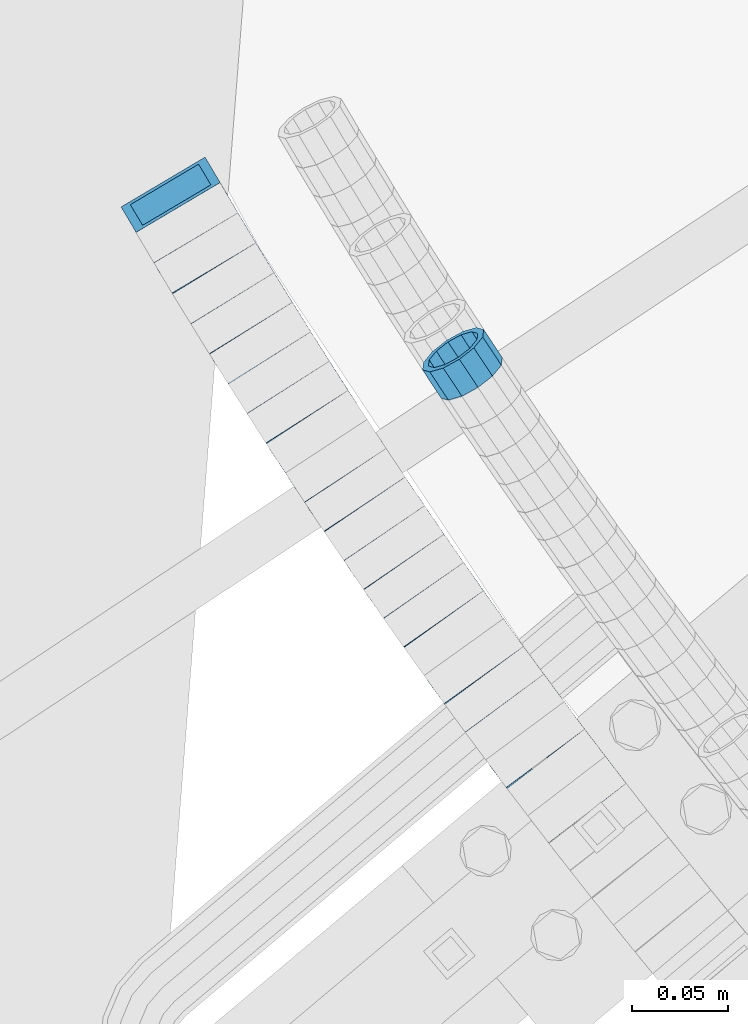
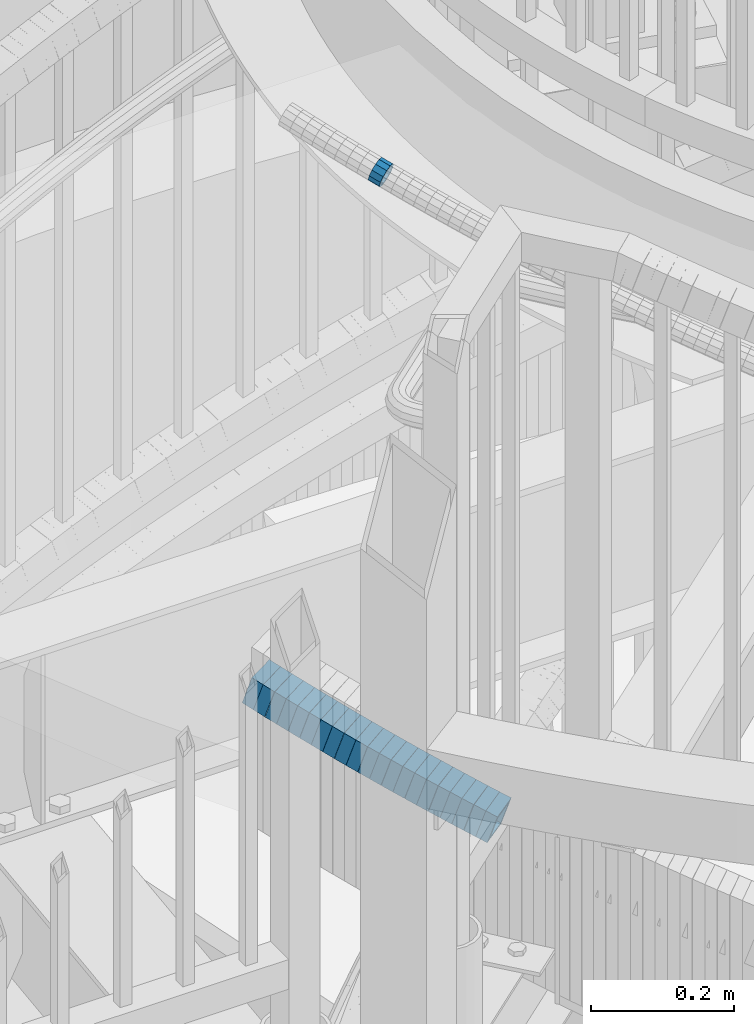
# One storey, part 656 of 975: 22 beams.
"""IFC2X3 building model written with IfcOpenShell, lengths in millimetres."""

import ifcopenshell
import ifcopenshell.guid

model = None  # the IFC model being written
_history = None  # IfcOwnerHistory: only IFC2X3 demands one
_inside = {}  # id of a spatial element -> (the spatial element, [elements in it])
_under = {}  # id of a project, library or spatial element -> (it, [spatial elements below it])
_declared = {}  # id of a project -> (the project, [libraries it declares])
_typed = {}  # id of a type object -> (the type object, [elements of that type])
_made_of = {}  # id of a material, layer set ... -> (it, [elements and type objects made of it])


def new_model(schema):
    """Start an empty IFC model of exactly this schema.

    Asked for "IFC4X3", IfcOpenShell would pick the latest addendum, in which some entities
    have other attributes; the version numbers below select the first issue.
    IFC2X3 requires an IfcOwnerHistory on every rooted entity: one is made here for all.
    """
    global model, _history
    if schema == "IFC4X3":
        model = ifcopenshell.file(schema_version=(4, 3, 0, 0))
    else:
        model = ifcopenshell.file(schema=schema)
    _inside.clear()
    _under.clear()
    _declared.clear()
    _typed.clear()
    _made_of.clear()
    _history = None
    if model.schema == "IFC2X3":
        org = make("IfcOrganization", Name="unknown")
        user = make(
            "IfcPersonAndOrganization",
            ThePerson=make("IfcPerson", FamilyName="unknown"),
            TheOrganization=org,
        )
        app = make(
            "IfcApplication",
            ApplicationDeveloper=org,
            Version="unknown",
            ApplicationFullName="unknown",
            ApplicationIdentifier="unknown",
        )
        _history = make(
            "IfcOwnerHistory",
            OwningUser=user,
            OwningApplication=app,
            ChangeAction="ADDED",
            CreationDate=0,
        )
    return model


def make(cls, **values):
    """One entity of the class cls with the attributes given. An attribute that is None is left unset."""
    return model.create_entity(
        cls, **{name: value for name, value in values.items() if value is not None}
    )


def rooted(cls, **values):
    """An entity with a GlobalId (a new one), such as an element, a storey or a relation."""
    return make(cls, GlobalId=ifcopenshell.guid.new(), OwnerHistory=_history, **values)


def si_unit(unit_type, name, prefix=None):
    """IfcSIUnit, for example si_unit("LENGTHUNIT", "METRE", prefix="MILLI")."""
    return make("IfcSIUnit", UnitType=unit_type, Prefix=prefix, Name=name)


def assignment(units):
    """IfcUnitAssignment: the units of a project."""
    return None if units is None else make("IfcUnitAssignment", Units=units)


def point(xyz):
    """IfcCartesianPoint."""
    return None if xyz is None else make("IfcCartesianPoint", Coordinates=xyz)


def direction(xyz):
    """IfcDirection."""
    return None if xyz is None else make("IfcDirection", DirectionRatios=xyz)


def frame(location, z_axis=None, x_axis=None):
    """IfcAxis2Placement3D, a coordinate frame: its origin and axes. An axis left out is left unset."""
    return make(
        "IfcAxis2Placement3D",
        Location=point(location),
        Axis=direction(z_axis),
        RefDirection=direction(x_axis),
    )


def origin_with_axes():
    """The frame at (0, 0, 0) with the z axis (0, 0, 1) and the x axis (1, 0, 0) written out."""
    return frame((0.0, 0.0, 0.0), z_axis=(0.0, 0.0, 1.0), x_axis=(1.0, 0.0, 0.0))


def place(relative_to, where):
    """IfcLocalPlacement: puts the frame where relative to a parent placement (None: the world)."""
    return make(
        "IfcLocalPlacement", PlacementRelTo=relative_to, RelativePlacement=where
    )


def context(
    kind, dimensions, precision=None, world=None, true_north=None, identifier=None
):
    """IfcGeometricRepresentationContext, for example the 3D "Model" context."""
    return make(
        "IfcGeometricRepresentationContext",
        ContextIdentifier=identifier,
        ContextType=kind,
        CoordinateSpaceDimension=dimensions,
        Precision=precision,
        WorldCoordinateSystem=world,
        TrueNorth=true_north,
    )


def subcontext(parent, identifier, kind, view, scale=None):
    """IfcGeometricRepresentationSubContext, for example "Body" below "Model"."""
    return make(
        "IfcGeometricRepresentationSubContext",
        ContextIdentifier=identifier,
        ContextType=kind,
        ParentContext=parent,
        TargetScale=scale,
        TargetView=view,
    )


def project(units=None, contexts=None):
    """IfcProject with its units and contexts."""
    return rooted(
        "IfcProject",
        Name="project",
        RepresentationContexts=contexts,
        UnitsInContext=assignment(units),
    )


def spatial(cls, under=None, at=None, **own):
    """A site, building, storey or space (cls), placed at a placement, below another one or the project."""
    s = rooted(cls, ObjectPlacement=at, **own)
    if under is not None:
        _under.setdefault(under.id(), (under, []))[1].append(s)
    return s


def faces_of(points, faces, orient=None, outer=None):
    """IfcFace entities. A face is a list of loops; a loop is a list of indices into points, from 0.

    orient and outer hold one flag for each loop. By default every Orientation is true, the
    first loop of a face is its IfcFaceOuterBound and the others are IfcFaceBound.
    """
    made = []
    for i, loops in enumerate(faces):
        bounds = []
        for j, loop in enumerate(loops):
            is_outer = j == 0 if outer is None else outer[i][j]
            bounds.append(
                make(
                    "IfcFaceOuterBound" if is_outer else "IfcFaceBound",
                    Bound=make("IfcPolyLoop", Polygon=[points[k] for k in loop]),
                    Orientation=True if orient is None else orient[i][j],
                )
            )
        made.append(make("IfcFace", Bounds=bounds))
    return made


def faceted_brep(points, faces, orient=None, outer=None, voids=None):
    """IfcFacetedBrep: a solid bounded by flat faces; with voids (closed shells), ...WithVoids."""
    shared = [point(p) for p in points]
    hull = make("IfcClosedShell", CfsFaces=faces_of(shared, faces, orient, outer))
    if voids is None:
        return make("IfcFacetedBrep", Outer=hull)
    return make(
        "IfcFacetedBrepWithVoids",
        Outer=hull,
        Voids=[
            make(cls, CfsFaces=faces_of(shared, fs, o, b)) for cls, fs, o, b in voids
        ],
    )


def shape(context_of_items, identifier, shape_type, items):
    """IfcShapeRepresentation: the items that make up one representation, for example the "Body"."""
    return make(
        "IfcShapeRepresentation",
        ContextOfItems=context_of_items,
        RepresentationIdentifier=identifier,
        RepresentationType=shape_type,
        Items=items,
    )


def material(Name=None, Category=None):
    """IfcMaterial."""
    return make("IfcMaterial", Name=Name, Category=Category)


def made_of(thing, what):
    """Note that an element or type object is made of a material, layer set ...; save() writes the relation."""
    if what is not None:
        _made_of.setdefault(what.id(), (what, []))[1].append(thing)
    return thing


def type_object(cls, material=None, **own):
    """A type object (cls), such as IfcWallType, which elements share."""
    return made_of(rooted(cls, **own), material)


def element(
    cls,
    number,
    at=None,
    inside=None,
    cuts=None,
    type_object=None,
    material=None,
    context=None,
    identifier="Body",
    shape_type=None,
    held_by="IfcProductDefinitionShape",
    body=None,
    shapes=None,
    **own,
):
    """One element of the class cls, such as IfcWall. Its Tag is "e" and its number.

    at: its placement. inside: the storey or other place that contains it. cuts: it is an
    opening in that element (IfcRelVoidsElement). A single representation is given by context,
    identifier, shape_type and body (its items); several are given by shapes. held_by: the class
    of the entity that holds the representations. save() writes the other relations.
    """
    e = rooted(cls, Tag="e%d" % number, ObjectPlacement=at, **own)
    if body is not None:
        shapes = [shape(context, identifier, shape_type, body)]
    if shapes is not None:
        e.Representation = make(held_by, Representations=shapes)
    if inside is not None:
        _inside.setdefault(inside.id(), (inside, []))[1].append(e)
    if cuts is not None:
        rooted(
            "IfcRelVoidsElement", RelatingBuildingElement=cuts, RelatedOpeningElement=e
        )
    if type_object is not None:
        _typed.setdefault(type_object.id(), (type_object, []))[1].append(e)
    return made_of(e, material)


def aggregate(whole, parts):
    """IfcRelAggregates: a whole, such as a stair, and the parts it consists of."""
    return rooted("IfcRelAggregates", RelatingObject=whole, RelatedObjects=parts)


def save(model, path):
    """Write the relations noted so far, then the file.

    IfcRelAggregates (storeys below a building ...), IfcRelContainedInSpatialStructure (elements
    in a storey), IfcRelDefinesByType, IfcRelAssociatesMaterial and IfcRelDeclares: one each for
    every whole, place, type object, material and project.
    """
    for whole, parts in _under.values():
        aggregate(whole, parts)
    for where, things in _inside.values():
        rooted(
            "IfcRelContainedInSpatialStructure",
            RelatedElements=things,
            RelatingStructure=where,
        )
    for kind, things in _typed.values():
        rooted("IfcRelDefinesByType", RelatedObjects=things, RelatingType=kind)
    for what, things in _made_of.values():
        rooted("IfcRelAssociatesMaterial", RelatedObjects=things, RelatingMaterial=what)
    for by, libraries in _declared.values():
        rooted("IfcRelDeclares", RelatingContext=by, RelatedDefinitions=libraries)
    model.write(path)


model = new_model("IFC2X3")

# Units and contexts
model_context = context("Model", 3, precision=1e-05, world=origin_with_axes())
body_context = subcontext(model_context, "Body", "Model", "MODEL_VIEW")
ifc_project = project(units=[si_unit("LENGTHUNIT", "METRE", prefix="MILLI"), si_unit("AREAUNIT", "SQUARE_METRE"), si_unit("VOLUMEUNIT", "CUBIC_METRE"), si_unit("MASSUNIT", "GRAM", prefix="KILO"), si_unit("TIMEUNIT", "SECOND"), si_unit("PLANEANGLEUNIT", "RADIAN"), si_unit("SOLIDANGLEUNIT", "STERADIAN"), si_unit("THERMODYNAMICTEMPERATUREUNIT", "DEGREE_CELSIUS"), si_unit("LUMINOUSINTENSITYUNIT", "LUMEN")], contexts=[model_context])

# Site, building, storey
site_placement = place(None, origin_with_axes())
site = spatial("IfcSite", under=ifc_project, at=site_placement, CompositionType="ELEMENT")
building_placement = place(site_placement, origin_with_axes())
building = spatial("IfcBuilding", under=site, at=building_placement, Name="Undefined", CompositionType="ELEMENT")
storey_placement = place(building_placement, origin_with_axes())
storey = spatial("IfcBuildingStorey", under=building, at=storey_placement, Name="Undefined", CompositionType="ELEMENT", Elevation=0.0)

# Beams
ifc_material = material()
beam_type_1 = type_object("IfcBeamType", PredefinedType="NOTDEFINED")
beam_1_placement = place(storey_placement, frame((32397.0147372931, 1885.18095695464, 5117.00592832306), z_axis=(0.834661610484996, 0.550763103323556, 9.69521352089941e-13), x_axis=(0.523125832185072, -0.792778323280461, -0.312796889110645)))
element("IfcBeam", 1, at=beam_1_placement, inside=storey, type_object=beam_type_1, material=ifc_material, Name="WALL", context=body_context, shape_type="Brep", body=[
    faceted_brep([(-2.1246523829177e-07, -15.367000000002, 0.0), (-1.83998054126278e-07, -13.3082123799541, 7.68350000000009), (18.5442713526427, -13.3082123799486, 7.68349999999555), (18.544271352639, -15.3669999999893, -1.81898940354586e-12), (-1.06232619145885e-07, -7.68349999999919, 13.3082123799559), (18.5442713526427, -7.68349999999373, 13.3082123799541), (-3.63797880709171e-12, 3.63797880709171e-12, 15.3670000000002), (18.5442713526354, 5.45696821063757e-12, 15.3669999999947), (1.06225343188271e-07, 7.68350000000646, 13.3082123799559), (18.5442713526245, 7.68350000001192, 13.3082123799468), (1.8399441614747e-07, 13.308212379965, 7.68350000000009), (18.5442713526172, 13.3082123799704, 7.68349999998827), (2.12461600312963e-07, 15.3670000000093, 0.0), (18.5442713526027, 15.3670000000202, -1.45519152283669e-11), (1.8399441614747e-07, 13.308212379965, -7.68350000000009), (18.5442713526027, 13.3082123799759, -7.68350000001556), (1.06225343188271e-07, 7.68350000000646, -13.3082123799559), (18.5442713526027, 7.68350000002283, -13.3082123799686), (-3.63797880709171e-12, 3.63797880709171e-12, -15.3670000000002), (18.5442713526063, 2.18278728425503e-11, -15.3670000000129), (-1.06232619145885e-07, -7.68349999999919, -13.3082123799559), (18.5442713526209, -7.68349999998281, -13.3082123799632), (-1.83998054126278e-07, -13.3082123799541, -7.68350000000009), (18.5442713526318, -13.3082123799395, -7.68350000000646), (-2.63386027654633e-07, -19.0500000000029, 0.0), (-2.28097633225843e-07, -16.4977839420972, -9.52499999999964), (18.5442713526354, -16.4977839420808, -9.52500000000691), (18.5442713526427, -19.0499999999902, -1.81898940354586e-12), (-1.31691194837913e-07, -9.52500000000146, -16.4977839420935), (18.5442713526245, -9.52499999997963, -16.4977839421044), (-3.63797880709171e-12, 3.63797880709171e-12, -19.0500000000002), (18.5442713526099, 2.36468622460961e-11, -19.0500000000138), (1.31687556859106e-07, 9.52500000000509, -16.4977839420935), (18.544271352599, 9.5250000000251, -16.4977839421081), (2.28097633225843e-07, 16.4977839421044, -9.52499999999964), (18.5442713525917, 16.4977839421172, -9.52500000001601), (2.63382389675826e-07, 19.0500000000138, 0.0), (18.544271352599, 19.0500000000211, -1.45519152283669e-11), (2.28097633225843e-07, 16.4977839421044, 9.52499999999964), (18.5442713526136, 16.4977839421099, 9.52499999998872), (1.31687556859106e-07, 9.52500000000509, 16.4977839420935), (18.5442713526281, 9.52500000000873, 16.4977839420862), (-3.63797880709171e-12, 3.63797880709171e-12, 19.0500000000002), (18.5442713526427, 3.63797880709171e-12, 19.0499999999975), (-1.31691194837913e-07, -9.52500000000146, 16.4977839420935), (18.54427135265, -9.524999999996, 16.4977839420935), (-2.28097633225843e-07, -16.4977839420972, 9.52499999999964), (18.54427135265, -16.4977839420899, 9.52499999999964)], [[[0, 1, 2, 3]], [[1, 4, 5, 2]], [[4, 6, 7, 5]], [[6, 8, 9, 7]], [[8, 10, 11, 9]], [[10, 12, 13, 11]], [[12, 14, 15, 13]], [[14, 16, 17, 15]], [[16, 18, 19, 17]], [[18, 20, 21, 19]], [[20, 22, 23, 21]], [[22, 0, 3, 23]], [[24, 25, 26, 27]], [[25, 28, 29, 26]], [[28, 30, 31, 29]], [[30, 32, 33, 31]], [[32, 34, 35, 33]], [[34, 36, 37, 35]], [[36, 38, 39, 37]], [[38, 40, 41, 39]], [[40, 42, 43, 41]], [[42, 44, 45, 43]], [[44, 46, 47, 45]], [[46, 24, 27, 47]], [[29, 31, 33, 35, 37, 39, 41, 43, 45, 47, 27, 26], [5, 7, 9, 11, 13, 15, 17, 19, 21, 23, 3, 2]], [[46, 44, 42, 40, 38, 36, 34, 32, 30, 28, 25, 24], [22, 20, 18, 16, 14, 12, 10, 8, 6, 4, 1, 0]]]),
])
beam_type_2 = type_object("IfcBeamType", Name="HSS2X2X.188_TUBES", PredefinedType="NOTDEFINED")
beam_2_placement = place(storey_placement, frame((32250.0902876863, 1965.7485546787, 4242.99334868471), z_axis=(0.860380537679217, 0.509652166072923, 7.19055606168696e-11), x_axis=(0.485707570135991, -0.819957940229565, -0.302914398084807)))
element("IfcBeam", 2, at=beam_2_placement, inside=storey, type_object=beam_type_2, material=ifc_material, Name="WALL", ObjectType="HSS2X2X.188_TUBES", context=body_context, shape_type="Brep", body=[
    faceted_brep([(0.0, 20.6374999999753, -20.6375000000298), (0.0, -20.6375000000153, -20.6375000000153), (19.1473235727644, -20.6374999999953, -20.637500000008), (19.1473235727499, 20.6374999999935, -20.6375000000262), (0.0, -20.6374999999825, 20.6375000000335), (19.1473235727899, -20.6375000000007, 20.6375000000444), (0.0, 20.6375000000116, 20.6375000000189), (19.1473235727772, 20.637499999988, 20.6375000000226), (0.0, 25.3999999999724, -25.4000000000342), (0.0, 25.400000000016, 25.4000000000196), (19.1473235727753, 25.3999999999851, 25.4000000000306), (19.1473235727462, 25.3999999999942, -25.4000000000342), (0.0, -25.399999999976, 25.4000000000378), (19.1473235727935, -25.4000000000015, 25.4000000000487), (0.0, -25.400000000016, -25.4000000000196), (19.1473235727608, -25.3999999999942, -25.400000000016)], [[[0, 1, 2, 3]], [[1, 4, 5, 2]], [[4, 6, 7, 5]], [[6, 0, 3, 7]], [[8, 9, 10, 11]], [[9, 12, 13, 10]], [[12, 14, 15, 13]], [[14, 8, 11, 15]], [[13, 15, 11, 10], [5, 7, 3, 2]], [[14, 12, 9, 8], [6, 4, 1, 0]]]),
])
beam_3_placement = place(storey_placement, frame((32259.3294549026, 1950.10823719607, 4237.24272757799), z_axis=(0.858946974184472, 0.512064542357055, 6.8944245867897e-11), x_axis=(0.48701112800018, -0.816921892000355, -0.308964049000125)))
element("IfcBeam", 3, at=beam_3_placement, inside=storey, type_object=beam_type_2, material=ifc_material, Name="WALL", ObjectType="HSS2X2X.188_TUBES", context=body_context, shape_type="Brep", body=[
    faceted_brep([(0.0, 20.6374999999753, -20.6375000000298), (0.0, -20.6375000000153, -20.6375000000153), (19.0960728947011, -20.6374999999935, -20.6375000000153), (19.0960728946884, 20.6374999999971, -20.6375000000335), (0.0, -20.6374999999825, 20.6375000000335), (19.0960728947157, -20.6375000000062, 20.6375000000226), (0.0, 20.6375000000116, 20.6375000000189), (19.096072894703, 20.6374999999844, 20.637500000008), (0.0, 25.3999999999724, -25.4000000000342), (0.0, 25.400000000016, 25.4000000000196), (19.096072894703, 25.3999999999796, 25.4000000000124), (19.0960728946866, 25.399999999996, -25.4000000000378), (0.0, -25.399999999976, 25.4000000000378), (19.0960728947175, -25.4000000000051, 25.4000000000269), (0.0, -25.400000000016, -25.4000000000196), (19.0960728946993, -25.3999999999905, -25.4000000000196)], [[[0, 1, 2, 3]], [[1, 4, 5, 2]], [[4, 6, 7, 5]], [[6, 0, 3, 7]], [[8, 9, 10, 11]], [[9, 12, 13, 10]], [[12, 14, 15, 13]], [[14, 8, 11, 15]], [[13, 15, 11, 10], [5, 7, 3, 2]], [[14, 12, 9, 8], [6, 4, 1, 0]]]),
])
beam_4_placement = place(storey_placement, frame((32268.7748844232, 1934.08308993233, 4231.30167783261), z_axis=(0.852601252575669, 0.522562057660523, -1.88316334970295e-10), x_axis=(0.497839568037742, -0.812264559061597, -0.303944157023068)))
element("IfcBeam", 4, at=beam_4_placement, inside=storey, type_object=beam_type_2, material=ifc_material, Name="WALL", ObjectType="HSS2X2X.188_TUBES", context=body_context, shape_type="Brep", body=[
    faceted_brep([(0.0, 20.6374999999753, -20.6375000000298), (0.0, -20.6375000000153, -20.6375000000153), (19.0824526725246, -20.6375000000098, -20.6375000000262), (19.0824526725428, 20.6375000000044, -20.6375000000044), (0.0, -20.6374999999825, 20.6375000000335), (19.0824526725391, -20.6375000000153, 20.6374999999898), (0.0, 20.6375000000116, 20.6375000000189), (19.0824526725555, 20.6374999999971, 20.6375000000153), (0.0, 25.3999999999724, -25.4000000000342), (0.0, 25.400000000016, 25.4000000000196), (19.0824526725592, 25.3999999999996, 25.4000000000233), (19.0824526725428, 25.4000000000069, -25.4000000000015), (0.0, -25.399999999976, 25.4000000000378), (19.0824526725391, -25.4000000000178, 25.3999999999905), (0.0, -25.400000000016, -25.4000000000196), (19.082452672521, -25.4000000000106, -25.4000000000342)], [[[0, 1, 2, 3]], [[1, 4, 5, 2]], [[4, 6, 7, 5]], [[6, 0, 3, 7]], [[8, 9, 10, 11]], [[9, 12, 13, 10]], [[12, 14, 15, 13]], [[14, 8, 11, 15]], [[13, 15, 11, 10], [5, 7, 3, 2]], [[14, 12, 9, 8], [6, 4, 1, 0]]]),
])
beam_5_placement = place(storey_placement, frame((32278.2770067394, 1918.5369817553, 4225.51221989357), z_axis=(0.851088555876138, 0.52502216149099, 1.54790541273541e-10), x_axis=(0.49996537788202, -0.810470190808751, -0.305242019927984)))
element("IfcBeam", 5, at=beam_5_placement, inside=storey, type_object=beam_type_2, material=ifc_material, Name="WALL", ObjectType="HSS2X2X.188_TUBES", context=body_context, shape_type="Brep", body=[
    faceted_brep([(0.0, 20.6374999999753, -20.6375000000298), (0.0, -20.6375000000153, -20.6375000000153), (19.0013157439425, -20.637500000008, -20.6374999999607), (19.0013157439371, 20.6374999999971, -20.637499999968), (0.0, -20.6374999999825, 20.6375000000335), (19.0013157439262, -20.6374999999935, 20.6375000000116), (0.0, 20.6375000000116, 20.6375000000189), (19.0013157439207, 20.6375000000116, 20.637500000008), (0.0, 25.3999999999724, -25.4000000000342), (0.0, 25.400000000016, 25.4000000000196), (19.0013157439171, 25.4000000000124, 25.4000000000015), (19.0013157439407, 25.399999999996, -25.3999999999651), (0.0, -25.399999999976, 25.4000000000378), (19.0013157439244, -25.3999999999924, 25.4000000000087), (0.0, -25.400000000016, -25.4000000000196), (19.0013157439444, -25.4000000000087, -25.3999999999578)], [[[0, 1, 2, 3]], [[1, 4, 5, 2]], [[4, 6, 7, 5]], [[6, 0, 3, 7]], [[8, 9, 10, 11]], [[9, 12, 13, 10]], [[12, 14, 15, 13]], [[14, 8, 11, 15]], [[13, 15, 11, 10], [5, 7, 3, 2]], [[14, 12, 9, 8], [6, 4, 1, 0]]]),
])
beam_6_placement = place(storey_placement, frame((32287.8196908273, 1902.99924574157, 4219.70568187766), z_axis=(0.84861688225198, 0.529007927310102, 2.10578946280293e-10), x_axis=(0.503897090052248, -0.80833491408383, -0.304437825031588)))
element("IfcBeam", 6, at=beam_6_placement, inside=storey, type_object=beam_type_2, material=ifc_material, Name="WALL", ObjectType="HSS2X2X.188_TUBES", context=body_context, shape_type="Brep", body=[
    faceted_brep([(0.0, 20.6374999999753, -20.6375000000298), (0.0, -20.6375000000153, -20.6375000000153), (19.0515091265825, -20.6374999999989, -20.6374999999825), (19.0515091265752, 20.6375000000116, -20.6375000000044), (0.0, -20.6374999999825, 20.6375000000335), (19.0515091265916, -20.6375000000207, 20.637500000048), (0.0, 20.6375000000116, 20.6375000000189), (19.0515091265843, 20.6374999999898, 20.6375000000262), (0.0, 25.3999999999724, -25.4000000000342), (0.0, 25.400000000016, 25.4000000000196), (19.0515091265825, 25.3999999999887, 25.4000000000269), (19.0515091265715, 25.4000000000142, -25.400000000016), (0.0, -25.399999999976, 25.4000000000378), (19.0515091265952, -25.4000000000251, 25.4000000000597), (0.0, -25.400000000016, -25.4000000000196), (19.0515091265825, -25.3999999999978, -25.3999999999833)], [[[0, 1, 2, 3]], [[1, 4, 5, 2]], [[4, 6, 7, 5]], [[6, 0, 3, 7]], [[8, 9, 10, 11]], [[9, 12, 13, 10]], [[12, 14, 15, 13]], [[14, 8, 11, 15]], [[13, 15, 11, 10], [5, 7, 3, 2]], [[14, 12, 9, 8], [6, 4, 1, 0]]]),
])
for number, where, z_axis, x_axis, name in (
    (7, (32297.4695969665, 1887.36640821885, 4213.92011794034), (0.842975720116068, 0.537951610551354, -1.41735654324293e-10), (0.512110492189128, -0.802482421296357, -0.306210397113073), "WALL"),
    (8, (32307.1695969665, 1872.16640821885, 4208.12011794034), (0.842975720116068, 0.537951610551354, -1.41735654324293e-10), (0.512110492189128, -0.802482421296357, -0.306210397113073), "WALL"),
):
    element("IfcBeam", number, at=place(storey_placement, frame(where, z_axis=z_axis, x_axis=x_axis)), inside=storey, type_object=beam_type_2, material=ifc_material, Name=name, ObjectType="HSS2X2X.188_TUBES", context=body_context, shape_type="Brep", body=[
        faceted_brep([(0.0, 20.6374999999753, -20.6375000000298), (0.0, -20.6375000000153, -20.6375000000153), (18.9372648500248, -20.6375000000098, -20.6374999999716), (18.9372648499939, 20.637500000008, -20.6375000000189), (0.0, -20.6374999999825, 20.6375000000335), (18.9372648500175, -20.6375000000007, 20.6375000000116), (0.0, 20.6375000000116, 20.6375000000189), (18.9372648499884, 20.6375000000153, 20.6374999999643), (0.0, 25.3999999999724, -25.4000000000342), (0.0, 25.400000000016, 25.4000000000196), (18.9372648499811, 25.4000000000196, 25.3999999999578), (18.9372648499884, 25.4000000000087, -25.4000000000233), (0.0, -25.399999999976, 25.4000000000378), (18.9372648500193, -25.4000000000033, 25.400000000016), (0.0, -25.400000000016, -25.4000000000196), (18.9372648500266, -25.4000000000124, -25.3999999999651)], [[[0, 1, 2, 3]], [[1, 4, 5, 2]], [[4, 6, 7, 5]], [[6, 0, 3, 7]], [[8, 9, 10, 11]], [[9, 12, 13, 10]], [[12, 14, 15, 13]], [[14, 8, 11, 15]], [[13, 15, 11, 10], [5, 7, 3, 2]], [[14, 12, 9, 8], [6, 4, 1, 0]]]),
    ])
beam_7_placement = place(storey_placement, frame((32316.9144109529, 1856.82948907239, 4202.31335669337), z_axis=(0.840459118679731, 0.541874957742181, -1.38352334033698e-11), x_axis=(0.515989619098183, -0.800310430152245, -0.3053816110581)))
element("IfcBeam", 9, at=beam_7_placement, inside=storey, type_object=beam_type_2, material=ifc_material, Name="WALL", ObjectType="HSS2X2X.188_TUBES", context=body_context, shape_type="Brep", body=[
    faceted_brep([(0.0, 20.6374999999753, -20.6375000000298), (0.0, -20.6375000000153, -20.6375000000153), (18.9907872401272, -20.6375000000025, -20.6374999999789), (18.9907872401127, 20.6375000000007, -20.6375000000116), (0.0, -20.6374999999825, 20.6375000000335), (18.9907872401418, -20.6375000000171, 20.6375000000626), (0.0, 20.6375000000116, 20.6375000000189), (18.9907872401291, 20.6374999999862, 20.6375000000298), (0.0, 25.3999999999724, -25.4000000000342), (0.0, 25.400000000016, 25.4000000000196), (18.9907872401272, 25.3999999999851, 25.4000000000306), (18.9907872401072, 25.4000000000033, -25.4000000000196), (0.0, -25.399999999976, 25.4000000000378), (18.9907872401473, -25.4000000000196, 25.4000000000669), (0.0, -25.400000000016, -25.4000000000196), (18.9907872401254, -25.4000000000015, -25.3999999999833)], [[[0, 1, 2, 3]], [[1, 4, 5, 2]], [[4, 6, 7, 5]], [[6, 0, 3, 7]], [[8, 9, 10, 11]], [[9, 12, 13, 10]], [[12, 14, 15, 13]], [[14, 8, 11, 15]], [[13, 15, 11, 10], [5, 7, 3, 2]], [[14, 12, 9, 8], [6, 4, 1, 0]]]),
])
beam_8_placement = place(storey_placement, frame((32326.7691270212, 1841.39318044604, 4196.52755469662), z_axis=(0.834609406352343, 0.550842208647984, 2.89660420094152e-10), x_axis=(0.524220597122522, -0.794273631185618, -0.307119137071787)))
element("IfcBeam", 10, at=beam_8_placement, inside=storey, type_object=beam_type_2, material=ifc_material, Name="WALL", ObjectType="HSS2X2X.188_TUBES", context=body_context, shape_type="Brep", body=[
    faceted_brep([(0.0, 20.6374999999753, -20.6375000000298), (0.0, -20.6375000000153, -20.6375000000153), (18.891267824034, -20.6375000000153, -20.6374999999971), (18.891267824034, 20.6375000000025, -20.637500000008), (0.0, -20.6374999999825, 20.6375000000335), (18.8912678240486, -20.6374999999989, 20.6375000000153), (0.0, 20.6375000000116, 20.6375000000189), (18.8912678240449, 20.6375000000189, 20.6375000000007), (0.0, 25.3999999999724, -25.4000000000342), (0.0, 25.400000000016, 25.4000000000196), (18.8912678240467, 25.4000000000215, 25.4000000000051), (18.8912678240304, 25.4000000000033, -25.4000000000124), (0.0, -25.399999999976, 25.4000000000378), (18.8912678240504, -25.3999999999996, 25.400000000016), (0.0, -25.400000000016, -25.4000000000196), (18.891267824034, -25.4000000000178, -25.3999999999978)], [[[0, 1, 2, 3]], [[1, 4, 5, 2]], [[4, 6, 7, 5]], [[6, 0, 3, 7]], [[8, 9, 10, 11]], [[9, 12, 13, 10]], [[12, 14, 15, 13]], [[14, 8, 11, 15]], [[13, 15, 11, 10], [5, 7, 3, 2]], [[14, 12, 9, 8], [6, 4, 1, 0]]]),
])
beam_9_placement = place(storey_placement, frame((32336.7160547092, 1826.25719176891, 4190.72057137198), z_axis=(0.832050294630691, 0.554700195785959, -1.70329258253332e-10), x_axis=(0.528044638140129, -0.79206695721017, -0.306265890081285)))
element("IfcBeam", 11, at=beam_9_placement, inside=storey, type_object=beam_type_2, material=ifc_material, Name="WALL", ObjectType="HSS2X2X.188_TUBES", context=body_context, shape_type="Brep", body=[
    faceted_brep([(0.0, 20.6374999999753, -20.6375000000298), (0.0, -20.6375000000153, -20.6375000000153), (18.9372648500248, -20.6375000000098, -20.6374999999716), (18.9372648499939, 20.637500000008, -20.6375000000189), (0.0, -20.6374999999825, 20.6375000000335), (18.9372648500175, -20.6375000000007, 20.6375000000116), (0.0, 20.6375000000116, 20.6375000000189), (18.9372648499884, 20.6375000000153, 20.6374999999643), (0.0, 25.3999999999724, -25.4000000000342), (0.0, 25.400000000016, 25.4000000000196), (18.9372648499811, 25.4000000000196, 25.3999999999578), (18.9372648499884, 25.4000000000087, -25.4000000000233), (0.0, -25.399999999976, 25.4000000000378), (18.9372648500193, -25.4000000000033, 25.400000000016), (0.0, -25.400000000016, -25.4000000000196), (18.9372648500266, -25.4000000000124, -25.3999999999651)], [[[0, 1, 2, 3]], [[1, 4, 5, 2]], [[4, 6, 7, 5]], [[6, 0, 3, 7]], [[8, 9, 10, 11]], [[9, 12, 13, 10]], [[12, 14, 15, 13]], [[14, 8, 11, 15]], [[13, 15, 11, 10], [5, 7, 3, 2]], [[14, 12, 9, 8], [6, 4, 1, 0]]]),
])
beam_10_placement = place(storey_placement, frame((32346.8379493841, 1810.96921421217, 4184.8850393727), z_axis=(0.827752230488746, 0.561093793336645, -2.60712113231421e-10), x_axis=(0.534915910017351, -0.789133373025616, -0.301883237009813)))
element("IfcBeam", 12, at=beam_10_placement, inside=storey, type_object=beam_type_2, material=ifc_material, Name="WALL", ObjectType="HSS2X2X.188_TUBES", context=body_context, shape_type="Brep", body=[
    faceted_brep([(0.0, 20.6374999999753, -20.6375000000298), (0.0, -20.6375000000153, -20.6375000000153), (18.8814724002259, -20.6375000000171, -20.6374999999753), (18.8814724002277, 20.6374999999916, -20.6374999999716), (0.0, -20.6374999999825, 20.6375000000335), (18.8814724002368, -20.6375000000062, 20.6375000000298), (0.0, 20.6375000000116, 20.6375000000189), (18.8814724002386, 20.6375000000025, 20.6375000000262), (0.0, 25.3999999999724, -25.4000000000342), (0.0, 25.400000000016, 25.4000000000196), (18.8814724002386, 25.4000000000051, 25.4000000000269), (18.8814724002277, 25.3999999999905, -25.399999999976), (0.0, -25.399999999976, 25.4000000000378), (18.8814724002368, -25.4000000000051, 25.4000000000269), (0.0, -25.400000000016, -25.4000000000196), (18.8814724002259, -25.4000000000196, -25.399999999976)], [[[0, 1, 2, 3]], [[1, 4, 5, 2]], [[4, 6, 7, 5]], [[6, 0, 3, 7]], [[8, 9, 10, 11]], [[9, 12, 13, 10]], [[12, 14, 15, 13]], [[14, 8, 11, 15]], [[13, 15, 11, 10], [5, 7, 3, 2]], [[14, 12, 9, 8], [6, 4, 1, 0]]]),
])
beam_11_placement = place(storey_placement, frame((32356.8757291109, 1796.1175697729, 4179.23451134792), z_axis=(0.825991119591471, 0.56368312938745, 1.78134541783948e-10), x_axis=(0.536286546161279, -0.78584563123631, -0.307966531092603)))
element("IfcBeam", 13, at=beam_11_placement, inside=storey, type_object=beam_type_2, material=ifc_material, Name="WALL", ObjectType="HSS2X2X.188_TUBES", context=body_context, shape_type="Brep", body=[
    faceted_brep([(0.0, 20.6374999999753, -20.6375000000298), (0.0, -20.6375000000153, -20.6375000000153), (18.8332159191086, -20.6374999999916, -20.6375000000153), (18.8332159190923, 20.6375000000062, -20.6375000000335), (0.0, -20.6374999999825, 20.6375000000335), (18.8332159191377, -20.6375000000062, 20.6375000000335), (0.0, 20.6375000000116, 20.6375000000189), (18.8332159191141, 20.6374999999916, 20.6375000000116), (0.0, 25.3999999999724, -25.4000000000342), (0.0, 25.400000000016, 25.4000000000196), (18.8332159191159, 25.3999999999905, 25.4000000000124), (18.8332159190886, 25.4000000000069, -25.4000000000415), (0.0, -25.399999999976, 25.4000000000378), (18.8332159191395, -25.4000000000069, 25.4000000000378), (0.0, -25.400000000016, -25.4000000000196), (18.8332159191104, -25.3999999999905, -25.400000000016)], [[[0, 1, 2, 3]], [[1, 4, 5, 2]], [[4, 6, 7, 5]], [[6, 0, 3, 7]], [[8, 9, 10, 11]], [[9, 12, 13, 10]], [[12, 14, 15, 13]], [[14, 8, 11, 15]], [[13, 15, 11, 10], [5, 7, 3, 2]], [[14, 12, 9, 8], [6, 4, 1, 0]]]),
])
beam_12_placement = place(storey_placement, frame((32367.1015560726, 1781.02831328982, 4173.39843596918), z_axis=(0.821588113548792, 0.570081548267734, 1.52022039401345e-10), x_axis=(0.54318366524401, -0.782823517351607, -0.303543813136327)))
element("IfcBeam", 14, at=beam_12_placement, inside=storey, type_object=beam_type_2, material=ifc_material, Name="WALL", ObjectType="HSS2X2X.188_TUBES", context=body_context, shape_type="Brep", body=[
    faceted_brep([(0.0, 20.6374999999753, -20.6375000000298), (0.0, -20.6375000000153, -20.6375000000153), (18.7771137292038, -20.637500000008, -20.6374999999862), (18.777113729182, 20.6375000000062, -20.6375000000189), (0.0, -20.6374999999825, 20.6375000000335), (18.7771137291729, -20.6374999999916, 20.6374999999753), (0.0, 20.6375000000116, 20.6375000000189), (18.7771137291529, 20.6375000000207, 20.6374999999389), (0.0, 25.3999999999724, -25.4000000000342), (0.0, 25.400000000016, 25.4000000000196), (18.7771137291475, 25.4000000000251, 25.3999999999287), (18.7771137291857, 25.4000000000051, -25.4000000000196), (0.0, -25.399999999976, 25.4000000000378), (18.7771137291711, -25.3999999999905, 25.3999999999724), (0.0, -25.400000000016, -25.4000000000196), (18.7771137292129, -25.4000000000124, -25.3999999999724)], [[[0, 1, 2, 3]], [[1, 4, 5, 2]], [[4, 6, 7, 5]], [[6, 0, 3, 7]], [[8, 9, 10, 11]], [[9, 12, 13, 10]], [[12, 14, 15, 13]], [[14, 8, 11, 15]], [[13, 15, 11, 10], [5, 7, 3, 2]], [[14, 12, 9, 8], [6, 4, 1, 0]]]),
])
beam_13_placement = place(storey_placement, frame((32377.2895230482, 1766.23986054821, 4167.74096997326), z_axis=(0.817122939314853, 0.576463443806678, -1.1019528756151e-10), x_axis=(0.548299120091774, -0.777200694130069, -0.308750961051663)))
element("IfcBeam", 15, at=beam_13_placement, inside=storey, type_object=beam_type_2, material=ifc_material, Name="WALL", ObjectType="HSS2X2X.188_TUBES", context=body_context, shape_type="Brep", body=[
    faceted_brep([(0.0, 20.6374999999753, -20.6375000000298), (0.0, -20.6375000000153, -20.6375000000153), (18.7853666454903, -20.6375000000535, -20.6375000000326), (18.785366645363, 20.6374999999862, -20.6375000000044), (0.0, -20.6374999999825, 20.6375000000335), (18.785366645352, -20.6375000000007, 20.6374999999989), (0.0, 20.6375000000116, 20.6375000000189), (18.7853666453102, 20.6375000000025, 20.6374999999753), (0.0, 25.3999999999724, -25.4000000000342), (0.0, 25.400000000016, 25.4000000000196), (18.7853666452065, 25.4000000000451, 25.4000000000351), (18.7853666453739, 25.3999999999833, -25.400000000006), (0.0, -25.399999999976, 25.4000000000378), (18.7853666497213, -25.399999993424, 25.3999999995158), (0.0, -25.400000000016, -25.4000000000196), (18.7853666455194, -25.4000000000633, -25.4000000000406)], [[[0, 1, 2, 3]], [[1, 4, 5, 2]], [[4, 6, 7, 5]], [[6, 0, 3, 7]], [[8, 9, 10, 11]], [[9, 12, 13, 10]], [[12, 14, 15, 13]], [[14, 8, 11, 15]], [[13, 15, 11, 10], [5, 7, 3, 2]], [[14, 12, 9, 8], [6, 4, 1, 0]]]),
])
beam_14_placement = place(storey_placement, frame((32387.7115850864, 1751.40643299604, 4161.89430571694), z_axis=(0.814486661793431, 0.580182279771275, -2.11284714168869e-11), x_axis=(0.552902161305901, -0.776189572429466, -0.303032915167687)))
element("IfcBeam", 16, at=beam_14_placement, inside=storey, type_object=beam_type_2, material=ifc_material, Name="WALL", ObjectType="HSS2X2X.188_TUBES", context=body_context, shape_type="Brep", body=[
    faceted_brep([(0.0, 20.6374999999753, -20.6375000000298), (0.0, -20.6375000000153, -20.6375000000153), (18.8066477608099, -20.6374999999862, -20.6375000000116), (18.8066477608172, 20.6375000000062, -20.6374999999971), (0.0, -20.6374999999825, 20.6375000000335), (18.8066477608463, -20.6375000000062, 20.6375000000407), (0.0, 20.6375000000116, 20.6375000000189), (18.8066477608536, 20.6374999999844, 20.637500000048), (0.0, 25.3999999999724, -25.4000000000342), (0.0, 25.400000000016, 25.4000000000196), (18.8066477608591, 25.3999999999814, 25.400000000056), (18.8066477608154, 25.4000000000051, -25.4000000000015), (0.0, -25.399999999976, 25.4000000000378), (18.8066477608518, -25.4000000000087, 25.4000000000451), (0.0, -25.400000000016, -25.4000000000196), (18.8066477608081, -25.3999999999851, -25.4000000000196)], [[[0, 1, 2, 3]], [[1, 4, 5, 2]], [[4, 6, 7, 5]], [[6, 0, 3, 7]], [[8, 9, 10, 11]], [[9, 12, 13, 10]], [[12, 14, 15, 13]], [[14, 8, 11, 15]], [[13, 15, 11, 10], [5, 7, 3, 2]], [[14, 12, 9, 8], [6, 4, 1, 0]]]),
])
beam_15_placement = place(storey_placement, frame((32398.1206864209, 1736.75057400697, 4156.20445651513), z_axis=(0.812595948879356, 0.582827439183211, 7.00165401212871e-11), x_axis=(0.555190025760515, -0.774063016666067, -0.304286840868723)))
element("IfcBeam", 17, at=beam_15_placement, inside=storey, type_object=beam_type_2, material=ifc_material, Name="WALL", ObjectType="HSS2X2X.188_TUBES", context=body_context, shape_type="Brep", body=[
    faceted_brep([(0.0, 20.6374999999753, -20.6375000000298), (0.0, -20.6375000000153, -20.6375000000153), (18.7347271129966, -20.6375000000116, -20.6375000000262), (18.7347271130257, 20.6374999999989, -20.6374999999935), (0.0, -20.6374999999825, 20.6375000000335), (18.7347271129947, -20.6375000000116, 20.6374999999607), (0.0, 20.6375000000116, 20.6375000000189), (18.7347271130147, 20.6375000000007, 20.6374999999898), (0.0, 25.3999999999724, -25.4000000000342), (0.0, 25.400000000016, 25.4000000000196), (18.7347271130166, 25.4000000000015, 25.3999999999905), (18.7347271130257, 25.3999999999996, -25.3999999999869), (0.0, -25.399999999976, 25.4000000000378), (18.7347271129875, -25.4000000000106, 25.3999999999505), (0.0, -25.400000000016, -25.4000000000196), (18.7347271130002, -25.4000000000124, -25.4000000000233)], [[[0, 1, 2, 3]], [[1, 4, 5, 2]], [[4, 6, 7, 5]], [[6, 0, 3, 7]], [[8, 9, 10, 11]], [[9, 12, 13, 10]], [[12, 14, 15, 13]], [[14, 8, 11, 15]], [[13, 15, 11, 10], [5, 7, 3, 2]], [[14, 12, 9, 8], [6, 4, 1, 0]]]),
])
beam_16_placement = place(storey_placement, frame((32408.6363838666, 1721.92913766419, 4150.49986562592), z_axis=(0.805336884073592, 0.592817428177207, 3.1585841497872e-11), x_axis=(0.564813441940968, -0.767293732919835, -0.303720435968248)))
element("IfcBeam", 18, at=beam_16_placement, inside=storey, type_object=beam_type_2, material=ifc_material, Name="WALL", ObjectType="HSS2X2X.188_TUBES", context=body_context, shape_type="Brep", body=[
    faceted_brep([(0.0, 20.6374999999753, -20.6375000000298), (0.0, -20.6375000000153, -20.6375000000153), (18.767258723612, -20.6375000000025, -20.6374999999862), (18.7672587236229, 20.6374999999953, -20.637499999968), (0.0, -20.6374999999825, 20.6375000000335), (18.767258723612, -20.6375000000135, 20.6375000000153), (0.0, 20.6375000000116, 20.6375000000189), (18.7672587236266, 20.6374999999844, 20.6375000000371), (0.0, 25.3999999999724, -25.4000000000342), (0.0, 25.400000000016, 25.4000000000196), (18.7672587236302, 25.3999999999814, 25.4000000000342), (18.7672587236229, 25.399999999996, -25.3999999999687), (0.0, -25.399999999976, 25.4000000000378), (18.7672587236157, -25.4000000000142, 25.400000000016), (0.0, -25.400000000016, -25.4000000000196), (18.767258723612, -25.4000000000015, -25.3999999999905)], [[[0, 1, 2, 3]], [[1, 4, 5, 2]], [[4, 6, 7, 5]], [[6, 0, 3, 7]], [[8, 9, 10, 11]], [[9, 12, 13, 10]], [[12, 14, 15, 13]], [[14, 8, 11, 15]], [[13, 15, 11, 10], [5, 7, 3, 2]], [[14, 12, 9, 8], [6, 4, 1, 0]]]),
])
beam_17_placement = place(storey_placement, frame((32419.1739275642, 1707.57001396563, 4144.84968740492), z_axis=(0.803358108992866, 0.595496220571891, -1.10680048237555e-10), x_axis=(0.566197633066482, -0.763832656089715, -0.309806252036406)))
element("IfcBeam", 19, at=beam_17_placement, inside=storey, type_object=beam_type_2, material=ifc_material, Name="WALL", ObjectType="HSS2X2X.188_TUBES", context=body_context, shape_type="Brep", body=[
    faceted_brep([(0.0, 20.6374999999753, -20.6375000000298), (0.0, -20.6375000000153, -20.6375000000153), (18.724849799155, -20.6375000000171, -20.6374999999425), (18.7248497991204, 20.6374999999989, -20.6375000000007), (0.0, -20.6374999999825, 20.6375000000335), (18.7248497991168, -20.6374999999953, 20.6375000000007), (0.0, 20.6375000000116, 20.6375000000189), (18.724849799084, 20.6375000000226, 20.6374999999498), (0.0, 25.3999999999724, -25.4000000000342), (0.0, 25.400000000016, 25.4000000000196), (18.7248497990731, 25.4000000000269, 25.399999999936), (18.7248497991204, 25.3999999999978, -25.3999999999978), (0.0, -25.399999999976, 25.4000000000378), (18.7248497991186, -25.3999999999942, 25.4000000000051), (0.0, -25.400000000016, -25.4000000000196), (18.7248497991604, -25.4000000000233, -25.3999999999323)], [[[0, 1, 2, 3]], [[1, 4, 5, 2]], [[4, 6, 7, 5]], [[6, 0, 3, 7]], [[8, 9, 10, 11]], [[9, 12, 13, 10]], [[12, 14, 15, 13]], [[14, 8, 11, 15]], [[13, 15, 11, 10], [5, 7, 3, 2]], [[14, 12, 9, 8], [6, 4, 1, 0]]]),
])
beam_18_placement = place(storey_placement, frame((32429.8471470094, 1693.17123678965, 4139.00996959345), z_axis=(0.803358108992866, 0.595496220571891, -1.10680048237555e-10), x_axis=(0.56712880683648, -0.765088861779408, -0.304965489912089)))
element("IfcBeam", 20, at=beam_18_placement, inside=storey, type_object=beam_type_2, material=ifc_material, Name="WALL", ObjectType="HSS2X2X.188_TUBES", context=body_context, shape_type="Brep", body=[
    faceted_brep([(0.0, 20.6374999999753, -20.6375000000298), (0.0, -20.6375000000153, -20.6375000000153), (18.6895692834223, -20.637499999988, -20.6374999999862), (18.6895692834369, 20.6374999999953, -20.6374999999534), (0.0, -20.6374999999825, 20.6375000000335), (18.6895692833914, -20.637499999988, 20.6374999999789), (0.0, 20.6375000000116, 20.6375000000189), (18.6895692834078, 20.6374999999953, 20.637500000008), (0.0, 25.3999999999724, -25.4000000000342), (0.0, 25.400000000016, 25.4000000000196), (18.6895692834059, 25.3999999999924, 25.4000000000087), (18.6895692834423, 25.3999999999942, -25.3999999999432), (0.0, -25.399999999976, 25.4000000000378), (18.6895692833878, -25.3999999999869, 25.3999999999687), (0.0, -25.400000000016, -25.4000000000196), (18.6895692834241, -25.3999999999869, -25.3999999999833)], [[[0, 1, 2, 3]], [[1, 4, 5, 2]], [[4, 6, 7, 5]], [[6, 0, 3, 7]], [[8, 9, 10, 11]], [[9, 12, 13, 10]], [[12, 14, 15, 13]], [[14, 8, 11, 15]], [[13, 15, 11, 10], [5, 7, 3, 2]], [[14, 12, 9, 8], [6, 4, 1, 0]]]),
])
for number, where, z_axis, x_axis, name in (
    (21, (32440.5810200064, 1678.49061448721, 4133.31496040186), (0.793878145952943, 0.608076877852068, -2.85062924376689e-11), (0.578990683923991, -0.755904503900802, -0.305578416959887), "WALL"),
    (22, (32451.3810200064, 1664.39061448721, 4127.61496040186), (0.793878145952943, 0.608076877852068, -2.85062924376689e-11), (0.578990683923991, -0.755904503900802, -0.305578416959887), "WALL"),
):
    element("IfcBeam", number, at=place(storey_placement, frame(where, z_axis=z_axis, x_axis=x_axis)), inside=storey, type_object=beam_type_2, material=ifc_material, Name=name, ObjectType="HSS2X2X.188_TUBES", context=body_context, shape_type="Brep", body=[
        faceted_brep([(0.0, 20.6374999999753, -20.6375000000298), (0.0, -20.6375000000153, -20.6375000000153), (18.6531498680506, -20.6374999999862, -20.6375000000007), (18.6531498680579, 20.637500000008, -20.6374999999935), (0.0, -20.6374999999825, 20.6375000000335), (18.6531498680379, -20.6374999999971, 20.6374999999789), (0.0, 20.6375000000116, 20.6375000000189), (18.6531498680451, 20.6374999999989, 20.6374999999898), (0.0, 25.3999999999724, -25.4000000000342), (0.0, 25.400000000016, 25.4000000000196), (18.653149868047, 25.399999999996, 25.3999999999869), (18.6531498680633, 25.4000000000087, -25.3999999999905), (0.0, -25.399999999976, 25.4000000000378), (18.6531498680361, -25.3999999999978, 25.3999999999796), (0.0, -25.400000000016, -25.4000000000196), (18.6531498680488, -25.3999999999851, -25.4000000000015)], [[[0, 1, 2, 3]], [[1, 4, 5, 2]], [[4, 6, 7, 5]], [[6, 0, 3, 7]], [[8, 9, 10, 11]], [[9, 12, 13, 10]], [[12, 14, 15, 13]], [[14, 8, 11, 15]], [[13, 15, 11, 10], [5, 7, 3, 2]], [[14, 12, 9, 8], [6, 4, 1, 0]]]),
    ])

save(model, "model.ifc")
